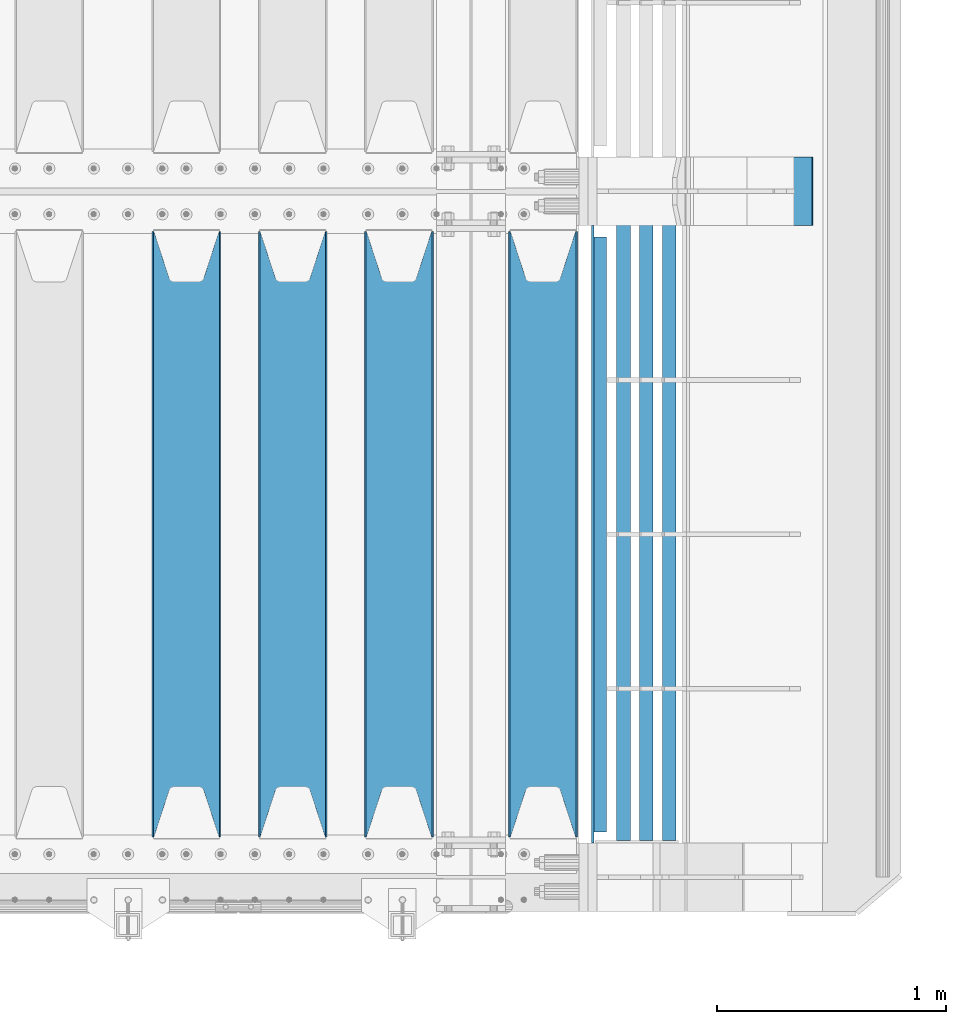
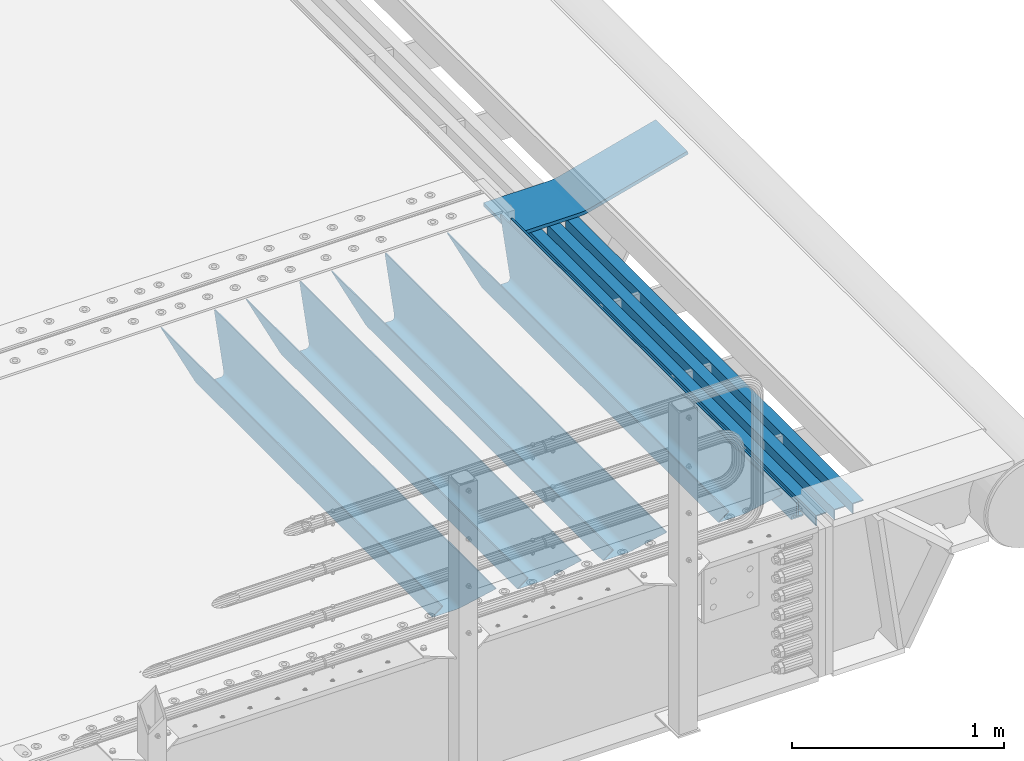
# One storey, part 131 of 247: 9 beams.
"""IFC2X3 building model written with IfcOpenShell, lengths in millimetres."""

from ifc_helpers import new_model, si_unit, frame, origin_with_axes, place, context, subcontext, project, spatial, faceted_brep, material, type_object, element, save


model = new_model("IFC2X3")

# Units and contexts
model_context = context("Model", 3, precision=1e-05, world=origin_with_axes())
body_context = subcontext(model_context, "Body", "Model", "MODEL_VIEW")
ifc_project = project(units=[si_unit("LENGTHUNIT", "METRE", prefix="MILLI"), si_unit("AREAUNIT", "SQUARE_METRE"), si_unit("VOLUMEUNIT", "CUBIC_METRE"), si_unit("MASSUNIT", "GRAM", prefix="KILO"), si_unit("TIMEUNIT", "SECOND"), si_unit("PLANEANGLEUNIT", "RADIAN"), si_unit("SOLIDANGLEUNIT", "STERADIAN"), si_unit("THERMODYNAMICTEMPERATUREUNIT", "DEGREE_CELSIUS"), si_unit("LUMINOUSINTENSITYUNIT", "LUMEN")], contexts=[model_context])

# Site, building, storey
site_placement = place(None, origin_with_axes())
site = spatial("IfcSite", under=ifc_project, at=site_placement, CompositionType="ELEMENT")
building_placement = place(site_placement, origin_with_axes())
building = spatial("IfcBuilding", under=site, at=building_placement, Name="Standard", CompositionType="ELEMENT")
storey_placement = place(building_placement, origin_with_axes())
storey = spatial("IfcBuildingStorey", under=building, at=storey_placement, Name="Undefined", CompositionType="ELEMENT", Elevation=0.0)

# Beams
ifc_material_1 = material(Name="STEEL/S355N")
beam_type_1 = type_object("IfcBeamType", PredefinedType="NOTDEFINED")
beam_1_placement = place(storey_placement, frame((16660.0, 175.0, -115.0), z_axis=(0.0, 0.0, 1.0), x_axis=(0.0, 1.0, 0.0)))
element("IfcBeam", 1, at=beam_1_placement, inside=storey, type_object=beam_type_1, material=ifc_material_1, context=body_context, shape_type="Brep", body=[
    faceted_brep([(0.0, 150.0, 115.0), (0.0, 143.689999999999, 115.0), (2650.00000000297, 143.689999999999, 115.0), (2650.00000000297, 150.0, 115.0), (2650.00000000297, 142.059565218402, 110.0000000031), (2650.00000000297, 148.369565218403, 110.0000000031), (2441.90079219208, -80.1103600731112, -98.0992078077845), (2437.7588105432, -77.5672621345584, -102.241189456673), (2434.06523489746, -74.4080125315522, -105.934765102404), (2430.91086095089, -70.710272125576, -109.089139048974), (2428.37322971128, -66.5649389910068, -111.626770288588), (2426.51472138054, -62.0739139532889, -113.485278619323), (2425.38102192091, -57.3475956567672, -114.618978078955), (2424.99999999987, -52.5021667386536, -115.0), (2424.99999999987, 52.5021667386536, -115.0), (2425.38102192091, 57.3475956567672, -114.618978078955), (2426.51472138054, 62.0739139532889, -113.485278619323), (2428.37322971128, 66.5649389910068, -111.626770288588), (2430.91086095089, 70.710272125576, -109.089139048974), (2434.06523489746, 74.4080125315522, -105.934765102404), (2437.7588105432, 77.5672621345584, -102.241189456673), (2441.90079219208, 80.1103600731112, -98.0992078077846), (2446.38936140511, 81.9747917625791, -93.6106385947584), (2448.24948500409, 76.2713538057251, -91.7505149957729), (2444.62967112262, 74.76777986261, -95.3703288772456), (2441.28936334126, 72.7168944282894, -98.710636658607), (2438.31067330438, 70.1691124903846, -101.689326695487), (2435.76682334747, 67.1870637758839, -104.233176652398), (2433.72034654133, 63.8440531834895, -106.279653458539), (2432.22154950041, 60.222258798236, -107.778450499454), (2431.30727574265, 56.4107117849089, -108.692724257221), (2430.99999999987, 52.5031078186876, -109.0), (2430.99999999987, -52.5031078186876, -109.0), (2431.30727574265, -56.4107117849089, -108.692724257221), (2432.22154950041, -60.222258798236, -107.778450499454), (2433.72034654133, -63.8440531834895, -106.279653458539), (2435.76682334747, -67.1870637758839, -104.233176652398), (2438.31067330438, -70.1691124903846, -101.689326695487), (2441.28936334126, -72.7168944282894, -98.7106366586071), (2444.62967112262, -74.76777986261, -95.3703288772457), (2448.24948500409, -76.2713538057251, -91.7505149957729), (2650.00000000297, -142.059565218402, 110.0000000031), (2650.00000000297, -148.369565218403, 110.0000000031), (2446.38936140511, -81.9747917625791, -93.6106385947584), (2650.00000000297, -143.689999999999, 115.0), (2650.00000000297, -150.0, 115.0), (0.0, -143.689999999999, 115.0), (0.0, -150.0, 115.0), (0.0, -148.369565218261, 110.000000002663), (203.610638597422, -81.9747917625791, -93.6106385947584), (208.099207810448, -80.1103600731112, -98.0992078077845), (212.241189459336, -77.5672621345584, -102.241189456673), (215.934765105068, -74.4080125315522, -105.934765102404), (219.089139051637, -70.710272125576, -109.089139048974), (221.626770291251, -66.5649389910068, -111.626770288588), (223.485278621985, -62.0739139532889, -113.485278619323), (224.618978081617, -57.3475956567672, -114.618978078955), (225.000000002663, -52.5021667386536, -115.0), (225.000000002663, 52.5021667386536, -115.0), (224.618978081617, 57.3475956567672, -114.618978078955), (223.485278621985, 62.0739139532889, -113.485278619323), (221.626770291251, 66.5649389910068, -111.626770288588), (219.089139051637, 70.710272125576, -109.089139048974), (215.934765105068, 74.4080125315522, -105.934765102404), (212.241189459336, 77.5672621345584, -102.241189456673), (208.099207810448, 80.1103600731112, -98.0992078077846), (203.610638597422, 81.9747917625791, -93.6106385947584), (0.0, 148.369565218261, 110.000000002663), (0.0, 142.05956521826, 110.000000002663), (201.750514998436, 76.2713538057251, -91.7505149957729), (205.370328879908, 74.76777986261, -95.3703288772456), (208.710636661271, 72.7168944282894, -98.710636658607), (211.68932669815, 70.1691124903846, -101.689326695487), (214.233176655061, 67.1870637758839, -104.233176652398), (216.279653461202, 63.8440531834895, -106.279653458539), (217.778450502117, 60.222258798236, -107.778450499454), (218.692724259885, 56.4107117849089, -108.692724257221), (219.000000002663, 52.5031078186876, -109.0), (219.000000002663, -52.5031078186876, -109.0), (218.692724259885, -56.4107117849089, -108.692724257221), (217.778450502117, -60.222258798236, -107.778450499454), (216.279653461202, -63.8440531834895, -106.279653458539), (214.233176655061, -67.1870637758839, -104.233176652398), (211.68932669815, -70.1691124903846, -101.689326695487), (208.710636661271, -72.7168944282894, -98.7106366586071), (205.370328879908, -74.76777986261, -95.3703288772457), (201.750514998436, -76.2713538057251, -91.7505149957729), (0.0, -142.05956521826, 110.000000002663)], [[[0, 1, 2, 3]], [[3, 2, 4, 5]], [[6, 7, 8, 9, 10, 11, 12, 13, 14, 15, 16, 17, 18, 19, 20, 21, 22, 5, 4, 23, 24, 25, 26, 27, 28, 29, 30, 31, 32, 33, 34, 35, 36, 37, 38, 39, 40, 41, 42, 43]], [[44, 45, 42, 41]], [[46, 47, 45, 44]], [[43, 42, 45, 47, 48, 49]], [[6, 43, 49, 50]], [[7, 6, 50, 51]], [[8, 7, 51, 52]], [[9, 8, 52, 53]], [[10, 9, 53, 54]], [[11, 10, 54, 55]], [[12, 11, 55, 56]], [[13, 12, 56, 57]], [[14, 13, 57, 58]], [[15, 14, 58, 59]], [[16, 15, 59, 60]], [[17, 16, 60, 61]], [[18, 17, 61, 62]], [[19, 18, 62, 63]], [[20, 19, 63, 64]], [[21, 20, 64, 65]], [[22, 21, 65, 66]], [[0, 3, 5, 22, 66, 67]], [[1, 0, 67, 68]], [[23, 4, 2, 1, 68, 69]], [[24, 23, 69, 70]], [[25, 24, 70, 71]], [[26, 25, 71, 72]], [[27, 26, 72, 73]], [[28, 27, 73, 74]], [[29, 28, 74, 75]], [[30, 29, 75, 76]], [[31, 30, 76, 77]], [[32, 31, 77, 78]], [[33, 32, 78, 79]], [[34, 33, 79, 80]], [[35, 34, 80, 81]], [[36, 35, 81, 82]], [[37, 36, 82, 83]], [[38, 37, 83, 84]], [[39, 38, 84, 85]], [[40, 39, 85, 86]], [[46, 44, 41, 40, 86, 87]], [[47, 46, 87, 48]], [[86, 85, 84, 83, 82, 81, 80, 79, 78, 77, 76, 75, 74, 73, 72, 71, 70, 69, 68, 67, 66, 65, 64, 63, 62, 61, 60, 59, 58, 57, 56, 55, 54, 53, 52, 51, 50, 49, 48, 87]]]),
])
beam_2_placement = place(storey_placement, frame((16030.0, 175.0, -115.0), z_axis=(0.0, 0.0, 1.0), x_axis=(0.0, 1.0, 0.0)))
element("IfcBeam", 2, at=beam_2_placement, inside=storey, type_object=beam_type_1, material=ifc_material_1, context=body_context, shape_type="Brep", body=[
    faceted_brep([(0.0, 150.0, 115.0), (0.0, 143.689999999999, 115.0), (2650.00000000297, 143.689999999999, 115.0), (2650.00000000297, 150.0, 115.0), (2650.00000000297, 142.059565218402, 110.0000000031), (2650.00000000297, 148.369565218403, 110.0000000031), (2441.90079219208, -80.1103600731112, -98.0992078077845), (2437.7588105432, -77.5672621345584, -102.241189456673), (2434.06523489746, -74.4080125315522, -105.934765102404), (2430.91086095089, -70.710272125576, -109.089139048974), (2428.37322971128, -66.5649389910068, -111.626770288588), (2426.51472138054, -62.0739139532889, -113.485278619323), (2425.38102192091, -57.3475956567672, -114.618978078955), (2424.99999999987, -52.5021667386536, -115.0), (2424.99999999987, 52.5021667386536, -115.0), (2425.38102192091, 57.3475956567672, -114.618978078955), (2426.51472138054, 62.0739139532889, -113.485278619323), (2428.37322971128, 66.5649389910068, -111.626770288588), (2430.91086095089, 70.710272125576, -109.089139048974), (2434.06523489746, 74.4080125315522, -105.934765102404), (2437.7588105432, 77.5672621345584, -102.241189456673), (2441.90079219208, 80.1103600731112, -98.0992078077846), (2446.38936140511, 81.9747917625791, -93.6106385947584), (2448.24948500409, 76.2713538057251, -91.7505149957729), (2444.62967112262, 74.76777986261, -95.3703288772456), (2441.28936334126, 72.7168944282894, -98.710636658607), (2438.31067330438, 70.1691124903846, -101.689326695487), (2435.76682334747, 67.1870637758839, -104.233176652398), (2433.72034654133, 63.8440531834895, -106.279653458539), (2432.22154950041, 60.222258798236, -107.778450499454), (2431.30727574265, 56.4107117849089, -108.692724257221), (2430.99999999987, 52.5031078186876, -109.0), (2430.99999999987, -52.5031078186876, -109.0), (2431.30727574265, -56.4107117849089, -108.692724257221), (2432.22154950041, -60.222258798236, -107.778450499454), (2433.72034654133, -63.8440531834895, -106.279653458539), (2435.76682334747, -67.1870637758839, -104.233176652398), (2438.31067330438, -70.1691124903846, -101.689326695487), (2441.28936334126, -72.7168944282894, -98.7106366586071), (2444.62967112262, -74.76777986261, -95.3703288772457), (2448.24948500409, -76.2713538057251, -91.7505149957729), (2650.00000000297, -142.059565218402, 110.0000000031), (2650.00000000297, -148.369565218403, 110.0000000031), (2446.38936140511, -81.9747917625791, -93.6106385947584), (2650.00000000297, -143.689999999999, 115.0), (2650.00000000297, -150.0, 115.0), (0.0, -143.689999999999, 115.0), (0.0, -150.0, 115.0), (0.0, -148.369565218261, 110.000000002663), (203.610638597422, -81.9747917625791, -93.6106385947584), (208.099207810448, -80.1103600731112, -98.0992078077845), (212.241189459336, -77.5672621345584, -102.241189456673), (215.934765105068, -74.4080125315522, -105.934765102404), (219.089139051637, -70.710272125576, -109.089139048974), (221.626770291251, -66.5649389910068, -111.626770288588), (223.485278621985, -62.0739139532889, -113.485278619323), (224.618978081617, -57.3475956567672, -114.618978078955), (225.000000002663, -52.5021667386536, -115.0), (225.000000002663, 52.5021667386536, -115.0), (224.618978081617, 57.3475956567672, -114.618978078955), (223.485278621985, 62.0739139532889, -113.485278619323), (221.626770291251, 66.5649389910068, -111.626770288588), (219.089139051637, 70.710272125576, -109.089139048974), (215.934765105068, 74.4080125315522, -105.934765102404), (212.241189459336, 77.5672621345584, -102.241189456673), (208.099207810448, 80.1103600731112, -98.0992078077846), (203.610638597422, 81.9747917625791, -93.6106385947584), (0.0, 148.369565218261, 110.000000002663), (0.0, 142.05956521826, 110.000000002663), (201.750514998436, 76.2713538057251, -91.7505149957729), (205.370328879908, 74.76777986261, -95.3703288772456), (208.710636661271, 72.7168944282894, -98.710636658607), (211.68932669815, 70.1691124903846, -101.689326695487), (214.233176655061, 67.1870637758839, -104.233176652398), (216.279653461202, 63.8440531834895, -106.279653458539), (217.778450502117, 60.222258798236, -107.778450499454), (218.692724259885, 56.4107117849089, -108.692724257221), (219.000000002663, 52.5031078186876, -109.0), (219.000000002663, -52.5031078186876, -109.0), (218.692724259885, -56.4107117849089, -108.692724257221), (217.778450502117, -60.222258798236, -107.778450499454), (216.279653461202, -63.8440531834895, -106.279653458539), (214.233176655061, -67.1870637758839, -104.233176652398), (211.68932669815, -70.1691124903846, -101.689326695487), (208.710636661271, -72.7168944282894, -98.7106366586071), (205.370328879908, -74.76777986261, -95.3703288772457), (201.750514998436, -76.2713538057251, -91.7505149957729), (0.0, -142.05956521826, 110.000000002663)], [[[0, 1, 2, 3]], [[3, 2, 4, 5]], [[6, 7, 8, 9, 10, 11, 12, 13, 14, 15, 16, 17, 18, 19, 20, 21, 22, 5, 4, 23, 24, 25, 26, 27, 28, 29, 30, 31, 32, 33, 34, 35, 36, 37, 38, 39, 40, 41, 42, 43]], [[44, 45, 42, 41]], [[46, 47, 45, 44]], [[43, 42, 45, 47, 48, 49]], [[6, 43, 49, 50]], [[7, 6, 50, 51]], [[8, 7, 51, 52]], [[9, 8, 52, 53]], [[10, 9, 53, 54]], [[11, 10, 54, 55]], [[12, 11, 55, 56]], [[13, 12, 56, 57]], [[14, 13, 57, 58]], [[15, 14, 58, 59]], [[16, 15, 59, 60]], [[17, 16, 60, 61]], [[18, 17, 61, 62]], [[19, 18, 62, 63]], [[20, 19, 63, 64]], [[21, 20, 64, 65]], [[22, 21, 65, 66]], [[0, 3, 5, 22, 66, 67]], [[1, 0, 67, 68]], [[23, 4, 2, 1, 68, 69]], [[24, 23, 69, 70]], [[25, 24, 70, 71]], [[26, 25, 71, 72]], [[27, 26, 72, 73]], [[28, 27, 73, 74]], [[29, 28, 74, 75]], [[30, 29, 75, 76]], [[31, 30, 76, 77]], [[32, 31, 77, 78]], [[33, 32, 78, 79]], [[34, 33, 79, 80]], [[35, 34, 80, 81]], [[36, 35, 81, 82]], [[37, 36, 82, 83]], [[38, 37, 83, 84]], [[39, 38, 84, 85]], [[40, 39, 85, 86]], [[46, 44, 41, 40, 86, 87]], [[47, 46, 87, 48]], [[86, 85, 84, 83, 82, 81, 80, 79, 78, 77, 76, 75, 74, 73, 72, 71, 70, 69, 68, 67, 66, 65, 64, 63, 62, 61, 60, 59, 58, 57, 56, 55, 54, 53, 52, 51, 50, 49, 48, 87]]]),
])
beam_3_placement = place(storey_placement, frame((15565.0, 175.0, -115.0), z_axis=(0.0, 0.0, 1.0), x_axis=(0.0, 1.0, 0.0)))
element("IfcBeam", 3, at=beam_3_placement, inside=storey, type_object=beam_type_1, material=ifc_material_1, context=body_context, shape_type="Brep", body=[
    faceted_brep([(0.0, 150.0, 115.0), (0.0, 143.689999999999, 115.0), (2650.00000000297, 143.689999999999, 115.0), (2650.00000000297, 150.0, 115.0), (2650.00000000297, 142.059565218402, 110.0000000031), (2650.00000000297, 148.369565218403, 110.0000000031), (2441.90079219208, -80.1103600731112, -98.0992078077845), (2437.7588105432, -77.5672621345584, -102.241189456673), (2434.06523489746, -74.4080125315522, -105.934765102404), (2430.91086095089, -70.710272125576, -109.089139048974), (2428.37322971128, -66.5649389910068, -111.626770288588), (2426.51472138054, -62.0739139532889, -113.485278619323), (2425.38102192091, -57.3475956567672, -114.618978078955), (2424.99999999987, -52.5021667386536, -115.0), (2424.99999999987, 52.5021667386536, -115.0), (2425.38102192091, 57.3475956567672, -114.618978078955), (2426.51472138054, 62.0739139532889, -113.485278619323), (2428.37322971128, 66.5649389910068, -111.626770288588), (2430.91086095089, 70.710272125576, -109.089139048974), (2434.06523489746, 74.4080125315522, -105.934765102404), (2437.7588105432, 77.5672621345584, -102.241189456673), (2441.90079219208, 80.1103600731112, -98.0992078077846), (2446.38936140511, 81.9747917625791, -93.6106385947584), (2448.24948500409, 76.2713538057251, -91.7505149957729), (2444.62967112262, 74.76777986261, -95.3703288772456), (2441.28936334126, 72.7168944282894, -98.710636658607), (2438.31067330438, 70.1691124903846, -101.689326695487), (2435.76682334747, 67.1870637758839, -104.233176652398), (2433.72034654133, 63.8440531834895, -106.279653458539), (2432.22154950041, 60.222258798236, -107.778450499454), (2431.30727574265, 56.4107117849089, -108.692724257221), (2430.99999999987, 52.5031078186876, -109.0), (2430.99999999987, -52.5031078186876, -109.0), (2431.30727574265, -56.4107117849089, -108.692724257221), (2432.22154950041, -60.222258798236, -107.778450499454), (2433.72034654133, -63.8440531834895, -106.279653458539), (2435.76682334747, -67.1870637758839, -104.233176652398), (2438.31067330438, -70.1691124903846, -101.689326695487), (2441.28936334126, -72.7168944282894, -98.7106366586071), (2444.62967112262, -74.76777986261, -95.3703288772457), (2448.24948500409, -76.2713538057251, -91.7505149957729), (2650.00000000297, -142.059565218402, 110.0000000031), (2650.00000000297, -148.369565218403, 110.0000000031), (2446.38936140511, -81.9747917625791, -93.6106385947584), (2650.00000000297, -143.689999999999, 115.0), (2650.00000000297, -150.0, 115.0), (0.0, -143.689999999999, 115.0), (0.0, -150.0, 115.0), (0.0, -148.369565218261, 110.000000002663), (203.610638597422, -81.9747917625791, -93.6106385947584), (208.099207810448, -80.1103600731112, -98.0992078077845), (212.241189459336, -77.5672621345584, -102.241189456673), (215.934765105068, -74.4080125315522, -105.934765102404), (219.089139051637, -70.710272125576, -109.089139048974), (221.626770291251, -66.5649389910068, -111.626770288588), (223.485278621985, -62.0739139532889, -113.485278619323), (224.618978081617, -57.3475956567672, -114.618978078955), (225.000000002663, -52.5021667386536, -115.0), (225.000000002663, 52.5021667386536, -115.0), (224.618978081617, 57.3475956567672, -114.618978078955), (223.485278621985, 62.0739139532889, -113.485278619323), (221.626770291251, 66.5649389910068, -111.626770288588), (219.089139051637, 70.710272125576, -109.089139048974), (215.934765105068, 74.4080125315522, -105.934765102404), (212.241189459336, 77.5672621345584, -102.241189456673), (208.099207810448, 80.1103600731112, -98.0992078077846), (203.610638597422, 81.9747917625791, -93.6106385947584), (0.0, 148.369565218261, 110.000000002663), (0.0, 142.05956521826, 110.000000002663), (201.750514998436, 76.2713538057251, -91.7505149957729), (205.370328879908, 74.76777986261, -95.3703288772456), (208.710636661271, 72.7168944282894, -98.710636658607), (211.68932669815, 70.1691124903846, -101.689326695487), (214.233176655061, 67.1870637758839, -104.233176652398), (216.279653461202, 63.8440531834895, -106.279653458539), (217.778450502117, 60.222258798236, -107.778450499454), (218.692724259885, 56.4107117849089, -108.692724257221), (219.000000002663, 52.5031078186876, -109.0), (219.000000002663, -52.5031078186876, -109.0), (218.692724259885, -56.4107117849089, -108.692724257221), (217.778450502117, -60.222258798236, -107.778450499454), (216.279653461202, -63.8440531834895, -106.279653458539), (214.233176655061, -67.1870637758839, -104.233176652398), (211.68932669815, -70.1691124903846, -101.689326695487), (208.710636661271, -72.7168944282894, -98.7106366586071), (205.370328879908, -74.76777986261, -95.3703288772457), (201.750514998436, -76.2713538057251, -91.7505149957729), (0.0, -142.05956521826, 110.000000002663)], [[[0, 1, 2, 3]], [[3, 2, 4, 5]], [[6, 7, 8, 9, 10, 11, 12, 13, 14, 15, 16, 17, 18, 19, 20, 21, 22, 5, 4, 23, 24, 25, 26, 27, 28, 29, 30, 31, 32, 33, 34, 35, 36, 37, 38, 39, 40, 41, 42, 43]], [[44, 45, 42, 41]], [[46, 47, 45, 44]], [[43, 42, 45, 47, 48, 49]], [[6, 43, 49, 50]], [[7, 6, 50, 51]], [[8, 7, 51, 52]], [[9, 8, 52, 53]], [[10, 9, 53, 54]], [[11, 10, 54, 55]], [[12, 11, 55, 56]], [[13, 12, 56, 57]], [[14, 13, 57, 58]], [[15, 14, 58, 59]], [[16, 15, 59, 60]], [[17, 16, 60, 61]], [[18, 17, 61, 62]], [[19, 18, 62, 63]], [[20, 19, 63, 64]], [[21, 20, 64, 65]], [[22, 21, 65, 66]], [[0, 3, 5, 22, 66, 67]], [[1, 0, 67, 68]], [[23, 4, 2, 1, 68, 69]], [[24, 23, 69, 70]], [[25, 24, 70, 71]], [[26, 25, 71, 72]], [[27, 26, 72, 73]], [[28, 27, 73, 74]], [[29, 28, 74, 75]], [[30, 29, 75, 76]], [[31, 30, 76, 77]], [[32, 31, 77, 78]], [[33, 32, 78, 79]], [[34, 33, 79, 80]], [[35, 34, 80, 81]], [[36, 35, 81, 82]], [[37, 36, 82, 83]], [[38, 37, 83, 84]], [[39, 38, 84, 85]], [[40, 39, 85, 86]], [[46, 44, 41, 40, 86, 87]], [[47, 46, 87, 48]], [[86, 85, 84, 83, 82, 81, 80, 79, 78, 77, 76, 75, 74, 73, 72, 71, 70, 69, 68, 67, 66, 65, 64, 63, 62, 61, 60, 59, 58, 57, 56, 55, 54, 53, 52, 51, 50, 49, 48, 87]]]),
])
beam_4_placement = place(storey_placement, frame((15100.0, 175.0, -115.0), z_axis=(0.0, 0.0, 1.0), x_axis=(0.0, 1.0, 0.0)))
element("IfcBeam", 4, at=beam_4_placement, inside=storey, type_object=beam_type_1, material=ifc_material_1, context=body_context, shape_type="Brep", body=[
    faceted_brep([(0.0, 150.0, 115.0), (0.0, 143.689999999999, 115.0), (2650.00000000297, 143.689999999999, 115.0), (2650.00000000297, 150.0, 115.0), (2650.00000000297, 142.059565218402, 110.0000000031), (2650.00000000297, 148.369565218403, 110.0000000031), (2441.90079219208, -80.1103600731112, -98.0992078077845), (2437.7588105432, -77.5672621345584, -102.241189456673), (2434.06523489746, -74.4080125315522, -105.934765102404), (2430.91086095089, -70.710272125576, -109.089139048974), (2428.37322971128, -66.5649389910068, -111.626770288588), (2426.51472138054, -62.0739139532889, -113.485278619323), (2425.38102192091, -57.3475956567672, -114.618978078955), (2424.99999999987, -52.5021667386536, -115.0), (2424.99999999987, 52.5021667386536, -115.0), (2425.38102192091, 57.3475956567672, -114.618978078955), (2426.51472138054, 62.0739139532889, -113.485278619323), (2428.37322971128, 66.5649389910068, -111.626770288588), (2430.91086095089, 70.710272125576, -109.089139048974), (2434.06523489746, 74.4080125315522, -105.934765102404), (2437.7588105432, 77.5672621345584, -102.241189456673), (2441.90079219208, 80.1103600731112, -98.0992078077846), (2446.38936140511, 81.9747917625791, -93.6106385947584), (2448.24948500409, 76.2713538057251, -91.7505149957729), (2444.62967112262, 74.76777986261, -95.3703288772456), (2441.28936334126, 72.7168944282894, -98.710636658607), (2438.31067330438, 70.1691124903846, -101.689326695487), (2435.76682334747, 67.1870637758839, -104.233176652398), (2433.72034654133, 63.8440531834895, -106.279653458539), (2432.22154950041, 60.222258798236, -107.778450499454), (2431.30727574265, 56.4107117849089, -108.692724257221), (2430.99999999987, 52.5031078186876, -109.0), (2430.99999999987, -52.5031078186876, -109.0), (2431.30727574265, -56.4107117849089, -108.692724257221), (2432.22154950041, -60.222258798236, -107.778450499454), (2433.72034654133, -63.8440531834895, -106.279653458539), (2435.76682334747, -67.1870637758839, -104.233176652398), (2438.31067330438, -70.1691124903846, -101.689326695487), (2441.28936334126, -72.7168944282894, -98.7106366586071), (2444.62967112262, -74.76777986261, -95.3703288772457), (2448.24948500409, -76.2713538057251, -91.7505149957729), (2650.00000000297, -142.059565218402, 110.0000000031), (2650.00000000297, -148.369565218403, 110.0000000031), (2446.38936140511, -81.9747917625791, -93.6106385947584), (2650.00000000297, -143.689999999999, 115.0), (2650.00000000297, -150.0, 115.0), (0.0, -143.689999999999, 115.0), (0.0, -150.0, 115.0), (0.0, -148.369565218261, 110.000000002663), (203.610638597422, -81.9747917625791, -93.6106385947584), (208.099207810448, -80.1103600731112, -98.0992078077845), (212.241189459336, -77.5672621345584, -102.241189456673), (215.934765105068, -74.4080125315522, -105.934765102404), (219.089139051637, -70.710272125576, -109.089139048974), (221.626770291251, -66.5649389910068, -111.626770288588), (223.485278621985, -62.0739139532889, -113.485278619323), (224.618978081617, -57.3475956567672, -114.618978078955), (225.000000002663, -52.5021667386536, -115.0), (225.000000002663, 52.5021667386536, -115.0), (224.618978081617, 57.3475956567672, -114.618978078955), (223.485278621985, 62.0739139532889, -113.485278619323), (221.626770291251, 66.5649389910068, -111.626770288588), (219.089139051637, 70.710272125576, -109.089139048974), (215.934765105068, 74.4080125315522, -105.934765102404), (212.241189459336, 77.5672621345584, -102.241189456673), (208.099207810448, 80.1103600731112, -98.0992078077846), (203.610638597422, 81.9747917625791, -93.6106385947584), (0.0, 148.369565218261, 110.000000002663), (0.0, 142.05956521826, 110.000000002663), (201.750514998436, 76.2713538057251, -91.7505149957729), (205.370328879908, 74.76777986261, -95.3703288772456), (208.710636661271, 72.7168944282894, -98.710636658607), (211.68932669815, 70.1691124903846, -101.689326695487), (214.233176655061, 67.1870637758839, -104.233176652398), (216.279653461202, 63.8440531834895, -106.279653458539), (217.778450502117, 60.222258798236, -107.778450499454), (218.692724259885, 56.4107117849089, -108.692724257221), (219.000000002663, 52.5031078186876, -109.0), (219.000000002663, -52.5031078186876, -109.0), (218.692724259885, -56.4107117849089, -108.692724257221), (217.778450502117, -60.222258798236, -107.778450499454), (216.279653461202, -63.8440531834895, -106.279653458539), (214.233176655061, -67.1870637758839, -104.233176652398), (211.68932669815, -70.1691124903846, -101.689326695487), (208.710636661271, -72.7168944282894, -98.7106366586071), (205.370328879908, -74.76777986261, -95.3703288772457), (201.750514998436, -76.2713538057251, -91.7505149957729), (0.0, -142.05956521826, 110.000000002663)], [[[0, 1, 2, 3]], [[3, 2, 4, 5]], [[6, 7, 8, 9, 10, 11, 12, 13, 14, 15, 16, 17, 18, 19, 20, 21, 22, 5, 4, 23, 24, 25, 26, 27, 28, 29, 30, 31, 32, 33, 34, 35, 36, 37, 38, 39, 40, 41, 42, 43]], [[44, 45, 42, 41]], [[46, 47, 45, 44]], [[43, 42, 45, 47, 48, 49]], [[6, 43, 49, 50]], [[7, 6, 50, 51]], [[8, 7, 51, 52]], [[9, 8, 52, 53]], [[10, 9, 53, 54]], [[11, 10, 54, 55]], [[12, 11, 55, 56]], [[13, 12, 56, 57]], [[14, 13, 57, 58]], [[15, 14, 58, 59]], [[16, 15, 59, 60]], [[17, 16, 60, 61]], [[18, 17, 61, 62]], [[19, 18, 62, 63]], [[20, 19, 63, 64]], [[21, 20, 64, 65]], [[22, 21, 65, 66]], [[0, 3, 5, 22, 66, 67]], [[1, 0, 67, 68]], [[23, 4, 2, 1, 68, 69]], [[24, 23, 69, 70]], [[25, 24, 70, 71]], [[26, 25, 71, 72]], [[27, 26, 72, 73]], [[28, 27, 73, 74]], [[29, 28, 74, 75]], [[30, 29, 75, 76]], [[31, 30, 76, 77]], [[32, 31, 77, 78]], [[33, 32, 78, 79]], [[34, 33, 79, 80]], [[35, 34, 80, 81]], [[36, 35, 81, 82]], [[37, 36, 82, 83]], [[38, 37, 83, 84]], [[39, 38, 84, 85]], [[40, 39, 85, 86]], [[46, 44, 41, 40, 86, 87]], [[47, 46, 87, 48]], [[86, 85, 84, 83, 82, 81, 80, 79, 78, 77, 76, 75, 74, 73, 72, 71, 70, 69, 68, 67, 66, 65, 64, 63, 62, 61, 60, 59, 58, 57, 56, 55, 54, 53, 52, 51, 50, 49, 48, 87]]]),
])
ifc_material_2 = material(Name="STEEL/S355J2")
beam_type_2 = type_object("IfcBeamType", PredefinedType="NOTDEFINED")
beam_5_placement = place(storey_placement, frame((16904.5025260065, 150.0, -124.999999999977), z_axis=(0.0, 0.0, 1.0), x_axis=(0.0, 1.0, 0.0)))
element("IfcBeam", 5, at=beam_5_placement, inside=storey, type_object=beam_type_2, material=ifc_material_2, context=body_context, shape_type="Brep", body=[
    faceted_brep([(2700.0, 22.5, -15.0), (2684.54915028125, 22.5, -17.4471741852423), (2684.54915028125, 32.5, -17.4471741852423), (2700.0, 32.5, -15.0), (2670.61073738538, 22.5, -24.5491502812526), (2670.61073738538, 32.5, -24.5491502812526), (2659.54915028125, 22.5, -35.6107373853764), (2659.54915028125, 32.5, -35.6107373853764), (2652.44717418524, 22.5, -49.5491502812526), (2652.44717418524, 32.5, -49.5491502812526), (2651.58384440324, -32.5, -55.0), (2650.0, -32.5, -65.0), (2650.0, 32.5, -65.0), (2651.58384440324, 22.5, -55.0), (0.0, 32.5, 65.0), (0.0, 22.5, 65.0), (2700.0, 22.5, 65.0), (2700.0, 32.5, 65.0), (0.0, 32.5, -15.0), (0.0, 22.5, -15.0), (15.4508497187474, 32.5, -17.4471741852423), (15.4508497187474, 22.5, -17.4471741852423), (29.3892626146236, 32.5, -24.5491502812526), (29.3892626146236, 22.5, -24.5491502812526), (40.4508497187473, 32.5, -35.6107373853763), (40.4508497187473, 22.5, -35.6107373853763), (47.5528258147577, 32.5, -49.5491502812526), (47.5528258147577, 22.5, -49.5491502812526), (50.0, -32.5, -65.0), (48.4161555967548, -32.5, -55.0), (48.4161555967548, 22.5, -55.0), (50.0, 32.5, -65.0)], [[[0, 1, 2, 3]], [[4, 5, 2, 1]], [[6, 7, 5, 4]], [[8, 9, 7, 6]], [[10, 11, 12, 9, 8, 13]], [[14, 15, 16, 17]], [[15, 14, 18, 19]], [[19, 18, 20, 21]], [[21, 20, 22, 23]], [[23, 22, 24, 25]], [[25, 24, 26, 27]], [[28, 29, 30, 27, 26, 31]], [[30, 29, 10, 13]], [[16, 15, 19, 21, 23, 25, 27, 30, 13, 8, 6, 4, 1, 0]], [[17, 16, 0, 3]], [[5, 7, 9, 12, 31, 26, 24, 22, 20, 18, 14, 17, 3, 2]], [[28, 31, 12, 11]], [[29, 28, 11, 10]]]),
])
beam_type_3 = type_object("IfcBeamType", PredefinedType="NOTDEFINED")
beam_6_placement = place(storey_placement, frame((16896.9988298906, 3000.0, -169.999999999995), z_axis=(0.0, -0.999999999999548, -9.5100000000016e-07), x_axis=(1.0, 0.0, 0.0)))
element("IfcBeam", 6, at=beam_6_placement, inside=storey, type_object=beam_type_3, material=ifc_material_1, context=body_context, shape_type="Brep", body=[
    faceted_brep([(0.0, 10.0, -150.0), (0.0, 10.0, 150.0), (356.495387467741, 10.0, 150.0), (356.495387467749, 9.99999999999901, -150.0), (0.0, -10.0, 150.0), (0.0, -10.0, -150.0), (356.495387467741, -10.0, -150.0), (356.495387467741, -10.0, 150.0), (382.770279632416, 11.7334369044542, 150.0), (382.770279632416, 11.7334369044542, -150.0), (385.397768848896, -8.09321940509935, -150.0), (385.397768848896, -8.09321940509935, 150.0), (413.799145684919, -2.40593045895554, -150.0), (413.799145684919, -2.40593045895554, 150.0), (408.589713119687, 16.9036995827646, 150.0), (408.589713119891, 16.9036995827009, -150.0), (939.000000000015, 160.0, 150.0), (939.000000000015, 160.0, -150.0), (944.209432565229, 140.69036995827, 150.0), (944.209432565229, 140.69036995827, -150.0)], [[[0, 1, 2, 3]], [[4, 5, 6, 7]], [[5, 4, 1, 0]], [[3, 2, 8, 9]], [[7, 6, 10, 11]], [[10, 12, 13, 11]], [[8, 14, 15, 9]], [[15, 14, 16, 17]], [[14, 8, 2, 1, 4, 7, 11, 13, 18, 16]], [[13, 12, 19, 18]], [[12, 10, 6, 5, 0, 3, 9, 15, 17, 19]], [[18, 19, 17, 16]]]),
])
beam_type_4 = type_object("IfcBeamType", PredefinedType="NOTDEFINED")
for number, where, z_axis, x_axis in (
    (7, (17212.0024147167, 2869.99999765913, -210.000211453654), (0.0, 0.0, -1.0), (4.09999996770818e-08, -0.999999999999996, 7.79999999985596e-08)),
    (8, (17112.0024147167, 2869.99999765913, -210.000211453654), (0.0, 0.0, -1.0), (4.09999996770818e-08, -0.999999999999996, 7.79999999985596e-08)),
    (9, (17012.002414716, 2869.99999765913, -210.000211453713), (0.0, 0.0, -1.0), (4.09999996770818e-08, -0.999999999999996, 7.79999999985596e-08)),
):
    element("IfcBeam", number, at=place(storey_placement, frame(where, z_axis=z_axis, x_axis=x_axis)), inside=storey, type_object=beam_type_4, material=ifc_material_2, context=body_context, shape_type="Brep", body=[
        faceted_brep([(4.54747350886464e-13, 30.0, -30.0), (4.54747350886464e-13, 30.0, 30.0000000000001), (2710.00000000001, 30.0, 30.0000000000001), (2710.00000000001, 30.0, -30.0), (4.54747350886464e-13, 24.0, 30.0), (2710.00000000001, 24.0, 30.0), (4.54747350886464e-13, 24.0, -24.0), (2710.00000000001, 24.0, -24.0), (4.54747350886464e-13, -30.0, -24.0), (2710.00000000001, -30.0, -24.0), (4.54747350886464e-13, -30.0, -30.0), (2710.00000000001, -30.0, -30.0)], [[[0, 1, 2, 3]], [[1, 4, 5, 2]], [[4, 6, 7, 5]], [[6, 8, 9, 7]], [[8, 10, 11, 9]], [[10, 0, 3, 11]], [[5, 7, 9, 11, 3, 2]], [[10, 8, 6, 4, 1, 0]]]),
    ])

save(model, "model.ifc")
